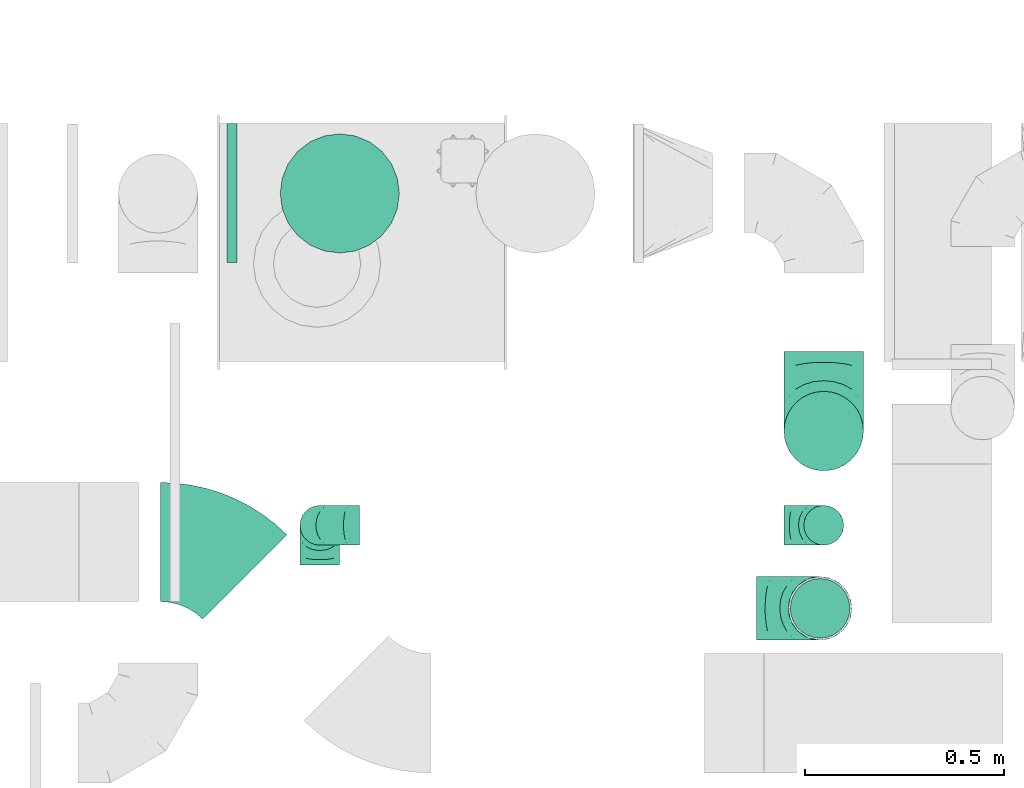
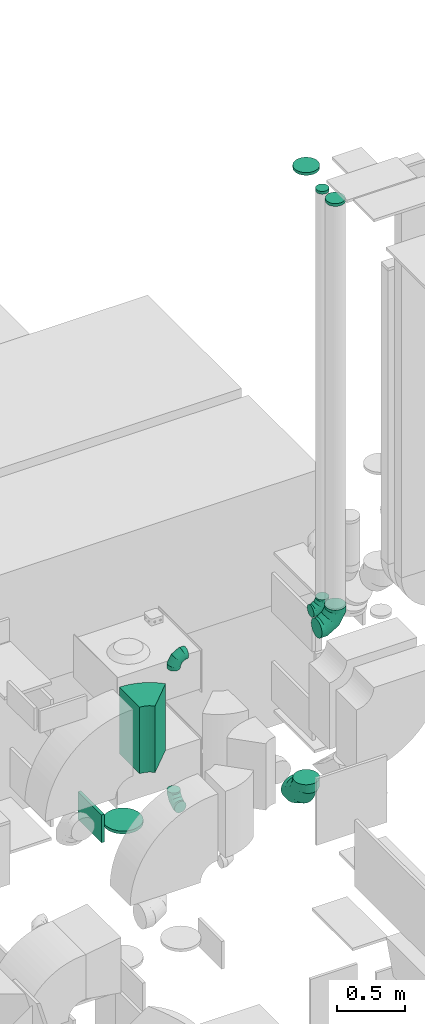
# One storey, part 18 of 59: 11 flow fittings.
"""IFC2X3 building model written with IfcOpenShell, lengths in millimetres."""

from ifc_helpers import new_model, entity, si_unit, converted_unit, derived_unit, direction, frame, frame_2d, origin, origin_2d_with_axis, place, context, subcontext, project, spatial, polyline, circle_curve, parameter, trimmed, segment, composite_curve, rectangle, circle, outline, extrude, faceted_brep, source, transform, mapped, material, type_object, type_shapes, element, save


model = new_model("IFC2X3")

# Units and contexts
model_context = context("Model", 3, precision=0.01, world=origin(), true_north=direction((6.12303176911189e-17, 1.0)))
body_context = subcontext(model_context, "Body", "Model", "MODEL_VIEW")
ifc_project = project(units=[si_unit("LENGTHUNIT", "METRE", prefix="MILLI"), si_unit("AREAUNIT", "SQUARE_METRE"), si_unit("VOLUMEUNIT", "CUBIC_METRE"), converted_unit("PLANEANGLEUNIT", "DEGREE", entity("IfcRatioMeasure", 0.0174532925199433), si_unit("PLANEANGLEUNIT", "RADIAN"), dimensions=[0, 0, 0, 0, 0, 0, 0]), si_unit("MASSUNIT", "GRAM", prefix="KILO"), derived_unit("MASSDENSITYUNIT", [(si_unit("MASSUNIT", "GRAM", prefix="KILO"), 1), (si_unit("LENGTHUNIT", "METRE"), -3)]), derived_unit("MOMENTOFINERTIAUNIT", [(si_unit("LENGTHUNIT", "METRE"), 4)]), si_unit("TIMEUNIT", "SECOND"), si_unit("FREQUENCYUNIT", "HERTZ"), si_unit("THERMODYNAMICTEMPERATUREUNIT", "DEGREE_CELSIUS"), derived_unit("THERMALTRANSMITTANCEUNIT", [(si_unit("MASSUNIT", "GRAM", prefix="KILO"), 1), (si_unit("THERMODYNAMICTEMPERATUREUNIT", "KELVIN"), -1), (si_unit("TIMEUNIT", "SECOND"), -3)]), derived_unit("VOLUMETRICFLOWRATEUNIT", [(si_unit("LENGTHUNIT", "METRE"), 3), (si_unit("TIMEUNIT", "SECOND"), -1)]), derived_unit("MASSFLOWRATEUNIT", [(si_unit("MASSUNIT", "GRAM", prefix="KILO"), 1), (si_unit("TIMEUNIT", "SECOND"), -1)]), derived_unit("ROTATIONALFREQUENCYUNIT", [(si_unit("TIMEUNIT", "SECOND"), -1)]), si_unit("ELECTRICCURRENTUNIT", "AMPERE"), si_unit("ELECTRICVOLTAGEUNIT", "VOLT"), si_unit("POWERUNIT", "WATT"), si_unit("FORCEUNIT", "NEWTON", prefix="KILO"), si_unit("ILLUMINANCEUNIT", "LUX"), si_unit("LUMINOUSFLUXUNIT", "LUMEN"), si_unit("LUMINOUSINTENSITYUNIT", "CANDELA"), derived_unit("USERDEFINED", [(si_unit("MASSUNIT", "GRAM", prefix="KILO"), -1), (si_unit("LENGTHUNIT", "METRE"), -2), (si_unit("TIMEUNIT", "SECOND"), 3), (si_unit("LUMINOUSFLUXUNIT", "LUMEN"), 1)]), derived_unit("LINEARVELOCITYUNIT", [(si_unit("LENGTHUNIT", "METRE"), 1), (si_unit("TIMEUNIT", "SECOND"), -1)]), si_unit("PRESSUREUNIT", "PASCAL"), derived_unit("USERDEFINED", [(si_unit("LENGTHUNIT", "METRE"), -2), (si_unit("MASSUNIT", "GRAM", prefix="KILO"), 1), (si_unit("TIMEUNIT", "SECOND"), -2)]), derived_unit("LINEARFORCEUNIT", [(si_unit("MASSUNIT", "GRAM", prefix="KILO"), 1), (si_unit("LENGTHUNIT", "METRE"), 1), (si_unit("TIMEUNIT", "SECOND"), -2), (si_unit("LENGTHUNIT", "METRE"), -1)]), derived_unit("PLANARFORCEUNIT", [(si_unit("MASSUNIT", "GRAM", prefix="KILO"), 1), (si_unit("LENGTHUNIT", "METRE"), 1), (si_unit("TIMEUNIT", "SECOND"), -2), (si_unit("LENGTHUNIT", "METRE"), -2)])], contexts=[model_context])

# Site, building, storey
site_placement = place(None, origin())
site = spatial("IfcSite", under=ifc_project, at=site_placement, CompositionType="ELEMENT")
building_placement = place(site_placement, origin())
building = spatial("IfcBuilding", under=site, at=building_placement, CompositionType="ELEMENT")
storey_placement = place(building_placement, frame((0.0, 0.0, 28200.0)))
storey = spatial("IfcBuildingStorey", under=building, at=storey_placement, CompositionType="ELEMENT", Elevation=28200.0)

# Flow fittings
ifc_material = material()
duct_fitting_type_1 = type_object("IfcDuctFittingType", PredefinedType="NOTDEFINED", material=ifc_material)
shared_shape_1 = source(origin(), body_context, "Body", "SweptSolid", [
    extrude(circle(Radius=49.9999999999997, at=origin_2d_with_axis()), frame((0.0, 0.0, 0.0), z_axis=(1.0, 0.0, 0.0), x_axis=(0.0, 1.0, 0.0)), (0.0, 0.0, 1.0), 25.0000000000018),
])
type_shapes(duct_fitting_type_1, [shared_shape_1])
flow_fitting_1_placement = place(storey_placement, frame((48370.11, 12162.74, 7463.42), z_axis=(-1.0, 0.0, 0.0), x_axis=(0.0, 0.0, 1.0)))
element("IfcFlowFitting", 1, at=flow_fitting_1_placement, inside=storey, type_object=duct_fitting_type_1, material=ifc_material, context=body_context, shape_type="MappedRepresentation", body=[
    mapped(shared_shape_1, transform((0.0, 0.0, 0.0), scale=1.0)),
])
duct_fitting_type_2 = type_object("IfcDuctFittingType", PredefinedType="NOTDEFINED", material=ifc_material)
shared_shape_2 = source(origin(), body_context, "Body", "SweptSolid", [
    extrude(circle(Radius=99.9999999999994, at=origin_2d_with_axis()), frame((0.0, 0.0, 0.0), z_axis=(1.0, 0.0, 0.0), x_axis=(0.0, 1.0, 0.0)), (0.0, 0.0, 1.0), 25.0000000000018),
])
type_shapes(duct_fitting_type_2, [shared_shape_2])
flow_fitting_2_placement = place(storey_placement, frame((48370.11, 12400.0, 7525.0), z_axis=(0.0, -1.0, 0.0), x_axis=(0.0, 0.0, 1.0)))
element("IfcFlowFitting", 2, at=flow_fitting_2_placement, inside=storey, type_object=duct_fitting_type_2, material=ifc_material, context=body_context, shape_type="MappedRepresentation", body=[
    mapped(shared_shape_2, transform((0.0, 0.0, 0.0), scale=1.0)),
])
duct_fitting_type_3 = type_object("IfcDuctFittingType", PredefinedType="NOTDEFINED", material=ifc_material)
shared_shape_3 = source(origin(), body_context, "Body", "SweptSolid", [
    extrude(rectangle(XDim=24.9999999999999, YDim=350.0, at=origin_2d_with_axis()), frame((12.5, 0.0, -125.0)), (0.0, 0.0, 1.0), 250.0),
])
type_shapes(duct_fitting_type_3, [shared_shape_3])
flow_fitting_3_placement = place(storey_placement, frame((46892.82, 12999.59, 1825.0), z_axis=(0.0, 0.0, 1.0), x_axis=(-1.0, 0.0, 0.0)))
element("IfcFlowFitting", 3, at=flow_fitting_3_placement, inside=storey, type_object=duct_fitting_type_3, material=ifc_material, context=body_context, shape_type="MappedRepresentation", body=[
    mapped(shared_shape_3, transform((0.0, 0.0, 0.0), scale=1.0)),
])
duct_fitting_type_4 = type_object("IfcDuctFittingType", PredefinedType="NOTDEFINED", material=ifc_material)
shared_shape_4 = source(origin(), body_context, "Body", "SweptSolid", [
    extrude(circle(Radius=74.9999999999995, at=origin_2d_with_axis()), frame((0.0, 0.0, 0.0), z_axis=(1.0, 0.0, 0.0), x_axis=(0.0, 1.0, 0.0)), (0.0, 0.0, 1.0), 25.0000000000018),
])
type_shapes(duct_fitting_type_4, [shared_shape_4])
flow_fitting_4_placement = place(storey_placement, frame((48361.04, 11953.77, 7501.2), z_axis=(-1.0, 0.0, 0.0), x_axis=(0.0, 0.0, 1.0)))
element("IfcFlowFitting", 4, at=flow_fitting_4_placement, inside=storey, type_object=duct_fitting_type_4, material=ifc_material, context=body_context, shape_type="MappedRepresentation", body=[
    mapped(shared_shape_4, transform((0.0, 0.0, 0.0), scale=1.0)),
])
duct_fitting_type_5 = type_object("IfcDuctFittingType", PredefinedType="NOTDEFINED", material=ifc_material)
shared_shape_5 = source(origin(), body_context, "Body", "Brep", [
    faceted_brep([(-160.0, 0.0, -80.0), (-160.0, -20.71, -77.27), (-160.0, -40.0, -69.28), (-160.0, -56.57, -56.57), (-160.0, -69.28, -40.0), (-160.0, -77.27, -20.71), (-160.0, -80.0, 0.0), (-160.0, -77.27, 20.71), (-160.0, -69.28, 40.0), (-160.0, -56.57, 56.57), (-160.0, -40.0, 69.28), (-160.0, -20.71, 77.27), (-160.0, 0.0, 80.0), (-160.0, 20.71, 77.27), (-160.0, 40.0, 69.28), (-160.0, 56.57, 56.57), (-160.0, 69.28, 40.0), (-160.0, 77.27, 20.71), (-160.0, 80.0, 0.0), (-160.0, 77.27, -20.71), (-160.0, 69.28, -40.0), (-160.0, 56.57, -56.57), (-160.0, 40.0, -69.28), (-160.0, 20.71, -77.27), (-122.68, 20.71, 77.27), (-127.85, 40.0, 69.28), (-117.13, 0.0, 80.0), (-132.29, 56.57, 56.57), (-137.83, 77.27, 20.71), (-138.56, 80.0, 0.0), (-135.69, 69.28, 40.0), (-135.69, 69.28, -40.0), (-132.29, 56.57, -56.57), (-137.83, 77.27, -20.71), (-122.68, 20.71, -77.27), (-117.13, 0.0, -80.0), (-127.85, 40.0, -69.28), (-111.58, -20.71, -77.27), (-106.41, -40.0, -69.28), (-101.97, -56.57, -56.57), (-98.56, -69.28, -40.0), (-96.42, -77.27, -20.71), (-95.69, -80.0, 0.0), (-96.42, -77.27, 20.71), (-98.56, -69.28, 40.0), (-101.97, -56.57, 56.57), (-106.41, -40.0, 69.28), (-111.58, -20.71, 77.27), (-58.03, 58.03, 77.27), (-72.15, 72.15, 69.28), (-42.87, 42.87, 80.0), (-84.28, 84.28, 56.57), (-93.59, 93.59, 40.0), (-99.44, 99.44, 20.71), (-101.44, 101.44, 0.0), (-99.44, 99.44, -20.71), (-93.59, 93.59, -40.0), (-84.28, 84.28, -56.57), (-58.03, 58.03, -77.27), (-42.87, 42.87, -80.0), (-72.15, 72.15, -69.28), (-27.71, 27.71, -77.27), (-13.59, 13.59, -69.28), (-1.46, 1.46, -56.57), (7.85, -7.85, -40.0), (13.7, -13.7, -20.71), (15.69, -15.69, 0.0), (13.7, -13.7, 20.71), (7.85, -7.85, 40.0), (-1.46, 1.46, 56.57), (-13.59, 13.59, 69.28), (-27.71, 27.71, 77.27), (-20.71, 122.68, 77.27), (-40.0, 127.85, 69.28), (0.0, 117.13, 80.0), (-56.57, 132.29, 56.57), (-69.28, 135.69, 40.0), (-77.27, 137.83, 20.71), (-80.0, 138.56, 0.0), (-77.27, 137.83, -20.71), (-69.28, 135.69, -40.0), (-56.57, 132.29, -56.57), (-20.71, 122.68, -77.27), (0.0, 117.13, -80.0), (-40.0, 127.85, -69.28), (20.71, 111.58, -77.27), (40.0, 106.41, -69.28), (56.57, 101.97, -56.57), (69.28, 98.56, -40.0), (77.27, 96.42, -20.71), (80.0, 95.69, 0.0), (77.27, 96.42, 20.71), (69.28, 98.56, 40.0), (56.57, 101.97, 56.57), (40.0, 106.41, 69.28), (20.71, 111.58, 77.27), (-20.71, 160.0, -77.27), (-40.0, 160.0, -69.28), (-56.57, 160.0, -56.57), (-69.28, 160.0, -40.0), (-77.27, 160.0, -20.71), (-80.0, 160.0, 0.0), (-77.27, 160.0, 20.71), (-69.28, 160.0, 40.0), (-56.57, 160.0, 56.57), (-40.0, 160.0, 69.28), (-20.71, 160.0, 77.27), (0.0, 160.0, 80.0), (20.71, 160.0, 77.27), (40.0, 160.0, 69.28), (56.57, 160.0, 56.57), (69.28, 160.0, 40.0), (77.27, 160.0, 20.71), (80.0, 160.0, 0.0), (77.27, 160.0, -20.71), (69.28, 160.0, -40.0), (56.57, 160.0, -56.57), (40.0, 160.0, -69.28), (20.71, 160.0, -77.27), (0.0, 160.0, -80.0)], [[[0, 1, 2, 3, 4, 5, 6, 7, 8, 9, 10, 11, 12, 13, 14, 15, 16, 17, 18, 19, 20, 21, 22, 23]], [[24, 25, 14, 13]], [[26, 24, 13, 12]], [[14, 25, 27, 15]], [[28, 29, 18, 17]], [[30, 28, 17, 16]], [[15, 27, 30, 16]], [[20, 31, 32, 21]], [[33, 31, 20, 19]], [[18, 29, 33, 19]], [[34, 35, 0, 23]], [[36, 34, 23, 22]], [[32, 36, 22, 21]], [[1, 0, 35, 37]], [[2, 1, 37, 38]], [[3, 2, 38, 39]], [[5, 4, 40, 41]], [[6, 5, 41, 42]], [[39, 40, 4, 3]], [[6, 42, 43, 7]], [[7, 43, 44, 8]], [[8, 44, 45, 9]], [[9, 45, 46, 10]], [[10, 46, 47, 11]], [[26, 12, 11, 47]], [[48, 49, 25, 24]], [[50, 48, 24, 26]], [[27, 25, 49, 51]], [[52, 53, 28, 30]], [[51, 52, 30, 27]], [[29, 28, 53, 54]], [[55, 56, 31, 33]], [[54, 55, 33, 29]], [[32, 31, 56, 57]], [[58, 59, 35, 34]], [[60, 58, 34, 36]], [[57, 60, 36, 32]], [[37, 35, 59, 61]], [[38, 37, 61, 62]], [[39, 38, 62, 63]], [[41, 40, 64, 65]], [[42, 41, 65, 66]], [[63, 64, 40, 39]], [[43, 42, 66, 67]], [[44, 43, 67, 68]], [[68, 69, 45, 44]], [[46, 45, 69, 70]], [[47, 46, 70, 71]], [[26, 47, 71, 50]], [[72, 73, 49, 48]], [[74, 72, 48, 50]], [[51, 49, 73, 75]], [[76, 77, 53, 52]], [[75, 76, 52, 51]], [[54, 53, 77, 78]], [[79, 80, 56, 55]], [[78, 79, 55, 54]], [[57, 56, 80, 81]], [[82, 83, 59, 58]], [[84, 82, 58, 60]], [[81, 84, 60, 57]], [[61, 59, 83, 85]], [[62, 61, 85, 86]], [[63, 62, 86, 87]], [[65, 64, 88, 89]], [[66, 65, 89, 90]], [[87, 88, 64, 63]], [[67, 66, 90, 91]], [[68, 67, 91, 92]], [[92, 93, 69, 68]], [[70, 69, 93, 94]], [[71, 70, 94, 95]], [[50, 71, 95, 74]], [[96, 97, 98, 99, 100, 101, 102, 103, 104, 105, 106, 107, 108, 109, 110, 111, 112, 113, 114, 115, 116, 117, 118, 119]], [[72, 74, 107, 106]], [[73, 72, 106, 105]], [[75, 73, 105, 104]], [[77, 76, 103, 102]], [[78, 77, 102, 101]], [[75, 104, 103, 76]], [[78, 101, 100, 79]], [[79, 100, 99, 80]], [[80, 99, 98, 81]], [[84, 97, 96, 82]], [[82, 96, 119, 83]], [[84, 81, 98, 97]], [[118, 117, 86, 85]], [[119, 118, 85, 83]], [[116, 87, 86, 117]], [[88, 115, 114, 89]], [[89, 114, 113, 90]], [[115, 88, 87, 116]], [[112, 111, 92, 91]], [[113, 112, 91, 90]], [[111, 110, 93, 92]], [[95, 94, 109, 108]], [[74, 95, 108, 107]], [[110, 109, 94, 93]]]),
])
type_shapes(duct_fitting_type_5, [shared_shape_5])
flow_fitting_5_placement = place(storey_placement, frame((48361.04, 11953.77, 3700.0), z_axis=(0.0, -1.0, 0.0), x_axis=(1.0, 0.0, 0.0)))
element("IfcFlowFitting", 5, at=flow_fitting_5_placement, inside=storey, type_object=duct_fitting_type_5, material=ifc_material, context=body_context, shape_type="MappedRepresentation", body=[
    mapped(shared_shape_5, transform((0.0, 0.0, 0.0), scale=1.0)),
])
duct_fitting_type_6 = type_object("IfcDuctFittingType", PredefinedType="NOTDEFINED", material=ifc_material)
shared_shape_6 = source(origin(), body_context, "Body", "Brep", [
    faceted_brep([(-100.0, 0.0, -50.0), (-100.0, -12.94, -48.3), (-100.0, -25.0, -43.3), (-100.0, -35.36, -35.36), (-100.0, -43.3, -25.0), (-100.0, -48.3, -12.94), (-100.0, -50.0, 0.0), (-100.0, -48.3, 12.94), (-100.0, -43.3, 25.0), (-100.0, -35.36, 35.36), (-100.0, -25.0, 43.3), (-100.0, -12.94, 48.3), (-100.0, 0.0, 50.0), (-100.0, 12.94, 48.3), (-100.0, 25.0, 43.3), (-100.0, 35.36, 35.36), (-100.0, 43.3, 25.0), (-100.0, 48.3, 12.94), (-100.0, 50.0, 0.0), (-100.0, 48.3, -12.94), (-100.0, 43.3, -25.0), (-100.0, 35.36, -35.36), (-100.0, 25.0, -43.3), (-100.0, 12.94, -48.3), (-76.67, 12.94, 48.3), (-79.9, 25.0, 43.3), (-73.21, 0.0, 50.0), (-82.68, 35.36, 35.36), (-86.15, 48.3, 12.94), (-86.6, 50.0, 0.0), (-84.81, 43.3, 25.0), (-84.81, 43.3, -25.0), (-82.68, 35.36, -35.36), (-86.15, 48.3, -12.94), (-76.67, 12.94, -48.3), (-73.21, 0.0, -50.0), (-79.9, 25.0, -43.3), (-69.74, -12.94, -48.3), (-66.51, -25.0, -43.3), (-63.73, -35.36, -35.36), (-61.6, -43.3, -25.0), (-60.26, -48.3, -12.94), (-59.81, -50.0, 0.0), (-60.26, -48.3, 12.94), (-61.6, -43.3, 25.0), (-63.73, -35.36, 35.36), (-66.51, -25.0, 43.3), (-69.74, -12.94, 48.3), (-36.27, 36.27, 48.3), (-45.1, 45.1, 43.3), (-26.79, 26.79, 50.0), (-52.68, 52.68, 35.36), (-58.49, 58.49, 25.0), (-62.15, 62.15, 12.94), (-63.4, 63.4, 0.0), (-62.15, 62.15, -12.94), (-58.49, 58.49, -25.0), (-52.68, 52.68, -35.36), (-36.27, 36.27, -48.3), (-26.79, 26.79, -50.0), (-45.1, 45.1, -43.3), (-17.32, 17.32, -48.3), (-8.49, 8.49, -43.3), (-0.91, 0.91, -35.36), (4.9, -4.9, -25.0), (8.56, -8.56, -12.94), (9.81, -9.81, 0.0), (8.56, -8.56, 12.94), (4.9, -4.9, 25.0), (-0.91, 0.91, 35.36), (-8.49, 8.49, 43.3), (-17.32, 17.32, 48.3), (-12.94, 76.67, 48.3), (-25.0, 79.9, 43.3), (0.0, 73.21, 50.0), (-35.36, 82.68, 35.36), (-43.3, 84.81, 25.0), (-48.3, 86.15, 12.94), (-50.0, 86.6, 0.0), (-48.3, 86.15, -12.94), (-43.3, 84.81, -25.0), (-35.36, 82.68, -35.36), (-12.94, 76.67, -48.3), (0.0, 73.21, -50.0), (-25.0, 79.9, -43.3), (12.94, 69.74, -48.3), (25.0, 66.51, -43.3), (35.36, 63.73, -35.36), (43.3, 61.6, -25.0), (48.3, 60.26, -12.94), (50.0, 59.81, 0.0), (48.3, 60.26, 12.94), (43.3, 61.6, 25.0), (35.36, 63.73, 35.36), (25.0, 66.51, 43.3), (12.94, 69.74, 48.3), (-12.94, 100.0, -48.3), (-25.0, 100.0, -43.3), (-35.36, 100.0, -35.36), (-43.3, 100.0, -25.0), (-48.3, 100.0, -12.94), (-50.0, 100.0, 0.0), (-48.3, 100.0, 12.94), (-43.3, 100.0, 25.0), (-35.36, 100.0, 35.36), (-25.0, 100.0, 43.3), (-12.94, 100.0, 48.3), (0.0, 100.0, 50.0), (12.94, 100.0, 48.3), (25.0, 100.0, 43.3), (35.36, 100.0, 35.36), (43.3, 100.0, 25.0), (48.3, 100.0, 12.94), (50.0, 100.0, 0.0), (48.3, 100.0, -12.94), (43.3, 100.0, -25.0), (35.36, 100.0, -35.36), (25.0, 100.0, -43.3), (12.94, 100.0, -48.3), (0.0, 100.0, -50.0)], [[[0, 1, 2, 3, 4, 5, 6, 7, 8, 9, 10, 11, 12, 13, 14, 15, 16, 17, 18, 19, 20, 21, 22, 23]], [[24, 25, 14, 13]], [[26, 24, 13, 12]], [[14, 25, 27, 15]], [[28, 29, 18, 17]], [[30, 28, 17, 16]], [[15, 27, 30, 16]], [[20, 31, 32, 21]], [[33, 31, 20, 19]], [[18, 29, 33, 19]], [[34, 35, 0, 23]], [[36, 34, 23, 22]], [[32, 36, 22, 21]], [[2, 1, 37, 38]], [[3, 2, 38, 39]], [[0, 35, 37, 1]], [[5, 4, 40, 41]], [[6, 5, 41, 42]], [[3, 39, 40, 4]], [[6, 42, 43, 7]], [[7, 43, 44, 8]], [[8, 44, 45, 9]], [[10, 46, 47, 11]], [[11, 47, 26, 12]], [[10, 9, 45, 46]], [[48, 49, 25, 24]], [[50, 48, 24, 26]], [[27, 25, 49, 51]], [[52, 53, 28, 30]], [[51, 52, 30, 27]], [[29, 28, 53, 54]], [[55, 56, 31, 33]], [[54, 55, 33, 29]], [[57, 32, 31, 56]], [[58, 59, 35, 34]], [[60, 58, 34, 36]], [[57, 60, 36, 32]], [[37, 35, 59, 61]], [[38, 37, 61, 62]], [[39, 38, 62, 63]], [[41, 40, 64, 65]], [[42, 41, 65, 66]], [[63, 64, 40, 39]], [[43, 42, 66, 67]], [[44, 43, 67, 68]], [[68, 69, 45, 44]], [[46, 45, 69, 70]], [[47, 46, 70, 71]], [[26, 47, 71, 50]], [[72, 73, 49, 48]], [[74, 72, 48, 50]], [[51, 49, 73, 75]], [[76, 77, 53, 52]], [[75, 76, 52, 51]], [[54, 53, 77, 78]], [[79, 80, 56, 55]], [[78, 79, 55, 54]], [[81, 57, 56, 80]], [[82, 83, 59, 58]], [[84, 82, 58, 60]], [[81, 84, 60, 57]], [[61, 59, 83, 85]], [[62, 61, 85, 86]], [[63, 62, 86, 87]], [[65, 64, 88, 89]], [[66, 65, 89, 90]], [[87, 88, 64, 63]], [[67, 66, 90, 91]], [[68, 67, 91, 92]], [[92, 93, 69, 68]], [[70, 69, 93, 94]], [[71, 70, 94, 95]], [[50, 71, 95, 74]], [[96, 97, 98, 99, 100, 101, 102, 103, 104, 105, 106, 107, 108, 109, 110, 111, 112, 113, 114, 115, 116, 117, 118, 119]], [[72, 74, 107, 106]], [[73, 72, 106, 105]], [[75, 73, 105, 104]], [[77, 76, 103, 102]], [[78, 77, 102, 101]], [[75, 104, 103, 76]], [[78, 101, 100, 79]], [[79, 100, 99, 80]], [[80, 99, 98, 81]], [[96, 119, 83, 82]], [[97, 96, 82, 84]], [[84, 81, 98, 97]], [[83, 119, 118, 85]], [[85, 118, 117, 86]], [[86, 117, 116, 87]], [[88, 115, 114, 89]], [[89, 114, 113, 90]], [[87, 116, 115, 88]], [[91, 90, 113, 112]], [[92, 91, 112, 111]], [[93, 92, 111, 110]], [[95, 94, 109, 108]], [[74, 95, 108, 107]], [[110, 109, 94, 93]]]),
])
type_shapes(duct_fitting_type_6, [shared_shape_6])
for number, where, z_axis, x_axis in (
    (6, (48370.11, 12162.74, 3703.42), (0.0, -1.0, 0.0), (1.0, 0.0, 0.0)),
    (7, (47101.64, 12162.74, 3703.42), (0.0, -1.0, 0.0), (-1.0, 0.0, 0.0)),
    (8, (47101.64, 12162.74, 2403.42), (-1.0, 0.0, 0.0), (0.0, 0.0, -1.0)),
):
    element("IfcFlowFitting", number, at=place(storey_placement, frame(where, z_axis=z_axis, x_axis=x_axis)), inside=storey, type_object=duct_fitting_type_6, material=ifc_material, context=body_context, shape_type="MappedRepresentation", body=[
        mapped(shared_shape_6, transform((0.0, 0.0, 0.0), scale=1.0)),
    ])
duct_fitting_type_7 = type_object("IfcDuctFittingType", PredefinedType="NOTDEFINED", material=ifc_material)
shared_shape_7 = source(origin(), body_context, "Body", "Brep", [
    faceted_brep([(-200.0, 0.0, -100.0), (-200.0, -25.88, -96.59), (-200.0, -50.0, -86.6), (-200.0, -70.71, -70.71), (-200.0, -86.6, -50.0), (-200.0, -96.59, -25.88), (-200.0, -100.0, 0.0), (-200.0, -96.59, 25.88), (-200.0, -86.6, 50.0), (-200.0, -70.71, 70.71), (-200.0, -50.0, 86.6), (-200.0, -25.88, 96.59), (-200.0, 0.0, 100.0), (-200.0, 25.88, 96.59), (-200.0, 50.0, 86.6), (-200.0, 70.71, 70.71), (-200.0, 86.6, 50.0), (-200.0, 96.59, 25.88), (-200.0, 100.0, 0.0), (-200.0, 96.59, -25.88), (-200.0, 86.6, -50.0), (-200.0, 70.71, -70.71), (-200.0, 50.0, -86.6), (-200.0, 25.88, -96.59), (-153.35, 25.88, 96.59), (-159.81, 50.0, 86.6), (-146.41, 0.0, 100.0), (-165.36, 70.71, 70.71), (-172.29, 96.59, 25.88), (-173.21, 100.0, 0.0), (-169.62, 86.6, 50.0), (-169.62, 86.6, -50.0), (-165.36, 70.71, -70.71), (-172.29, 96.59, -25.88), (-153.35, 25.88, -96.59), (-146.41, 0.0, -100.0), (-159.81, 50.0, -86.6), (-139.48, -25.88, -96.59), (-133.01, -50.0, -86.6), (-127.46, -70.71, -70.71), (-123.21, -86.6, -50.0), (-120.53, -96.59, -25.88), (-119.62, -100.0, 0.0), (-120.53, -96.59, 25.88), (-123.21, -86.6, 50.0), (-127.46, -70.71, 70.71), (-133.01, -50.0, 86.6), (-139.48, -25.88, 96.59), (-72.54, 72.54, 96.59), (-90.19, 90.19, 86.6), (-53.59, 53.59, 100.0), (-105.35, 105.35, 70.71), (-116.99, 116.99, 50.0), (-124.3, 124.3, 25.88), (-126.79, 126.79, 0.0), (-124.3, 124.3, -25.88), (-116.99, 116.99, -50.0), (-105.35, 105.35, -70.71), (-72.54, 72.54, -96.59), (-53.59, 53.59, -100.0), (-90.19, 90.19, -86.6), (-34.64, 34.64, -96.59), (-16.99, 16.99, -86.6), (-1.83, 1.83, -70.71), (9.81, -9.81, -50.0), (17.12, -17.12, -25.88), (19.62, -19.62, 0.0), (17.12, -17.12, 25.88), (9.81, -9.81, 50.0), (-1.83, 1.83, 70.71), (-16.99, 16.99, 86.6), (-34.64, 34.64, 96.59), (-25.88, 153.35, 96.59), (-50.0, 159.81, 86.6), (0.0, 146.41, 100.0), (-70.71, 165.36, 70.71), (-86.6, 169.62, 50.0), (-96.59, 172.29, 25.88), (-100.0, 173.21, 0.0), (-96.59, 172.29, -25.88), (-86.6, 169.62, -50.0), (-70.71, 165.36, -70.71), (-25.88, 153.35, -96.59), (0.0, 146.41, -100.0), (-50.0, 159.81, -86.6), (25.88, 139.48, -96.59), (50.0, 133.01, -86.6), (70.71, 127.46, -70.71), (86.6, 123.21, -50.0), (96.59, 120.53, -25.88), (100.0, 119.62, 0.0), (96.59, 120.53, 25.88), (86.6, 123.21, 50.0), (70.71, 127.46, 70.71), (50.0, 133.01, 86.6), (25.88, 139.48, 96.59), (-25.88, 200.0, -96.59), (-50.0, 200.0, -86.6), (-70.71, 200.0, -70.71), (-86.6, 200.0, -50.0), (-96.59, 200.0, -25.88), (-100.0, 200.0, 0.0), (-96.59, 200.0, 25.88), (-86.6, 200.0, 50.0), (-70.71, 200.0, 70.71), (-50.0, 200.0, 86.6), (-25.88, 200.0, 96.59), (0.0, 200.0, 100.0), (25.88, 200.0, 96.59), (50.0, 200.0, 86.6), (70.71, 200.0, 70.71), (86.6, 200.0, 50.0), (96.59, 200.0, 25.88), (100.0, 200.0, 0.0), (96.59, 200.0, -25.88), (86.6, 200.0, -50.0), (70.71, 200.0, -70.71), (50.0, 200.0, -86.6), (25.88, 200.0, -96.59), (0.0, 200.0, -100.0)], [[[0, 1, 2, 3, 4, 5, 6, 7, 8, 9, 10, 11, 12, 13, 14, 15, 16, 17, 18, 19, 20, 21, 22, 23]], [[24, 25, 14, 13]], [[26, 24, 13, 12]], [[14, 25, 27, 15]], [[28, 29, 18, 17]], [[30, 28, 17, 16]], [[15, 27, 30, 16]], [[20, 31, 32, 21]], [[33, 31, 20, 19]], [[18, 29, 33, 19]], [[34, 35, 0, 23]], [[36, 34, 23, 22]], [[32, 36, 22, 21]], [[1, 0, 35, 37]], [[2, 1, 37, 38]], [[38, 39, 3, 2]], [[5, 4, 40, 41]], [[6, 5, 41, 42]], [[39, 40, 4, 3]], [[6, 42, 43, 7]], [[7, 43, 44, 8]], [[8, 44, 45, 9]], [[9, 45, 46, 10]], [[10, 46, 47, 11]], [[26, 12, 11, 47]], [[48, 49, 25, 24]], [[50, 48, 24, 26]], [[27, 25, 49, 51]], [[52, 53, 28, 30]], [[51, 52, 30, 27]], [[29, 28, 53, 54]], [[55, 56, 31, 33]], [[54, 55, 33, 29]], [[32, 31, 56, 57]], [[58, 59, 35, 34]], [[60, 58, 34, 36]], [[57, 60, 36, 32]], [[37, 35, 59, 61]], [[38, 37, 61, 62]], [[39, 38, 62, 63]], [[41, 40, 64, 65]], [[42, 41, 65, 66]], [[63, 64, 40, 39]], [[43, 42, 66, 67]], [[44, 43, 67, 68]], [[68, 69, 45, 44]], [[46, 45, 69, 70]], [[47, 46, 70, 71]], [[26, 47, 71, 50]], [[72, 73, 49, 48]], [[74, 72, 48, 50]], [[51, 49, 73, 75]], [[76, 77, 53, 52]], [[75, 76, 52, 51]], [[54, 53, 77, 78]], [[79, 80, 56, 55]], [[78, 79, 55, 54]], [[57, 56, 80, 81]], [[82, 83, 59, 58]], [[84, 82, 58, 60]], [[81, 84, 60, 57]], [[61, 59, 83, 85]], [[62, 61, 85, 86]], [[63, 62, 86, 87]], [[65, 64, 88, 89]], [[66, 65, 89, 90]], [[87, 88, 64, 63]], [[67, 66, 90, 91]], [[68, 67, 91, 92]], [[92, 93, 69, 68]], [[70, 69, 93, 94]], [[71, 70, 94, 95]], [[50, 71, 95, 74]], [[96, 97, 98, 99, 100, 101, 102, 103, 104, 105, 106, 107, 108, 109, 110, 111, 112, 113, 114, 115, 116, 117, 118, 119]], [[72, 74, 107, 106]], [[73, 72, 106, 105]], [[75, 73, 105, 104]], [[102, 101, 78, 77]], [[103, 102, 77, 76]], [[75, 104, 103, 76]], [[78, 101, 100, 79]], [[79, 100, 99, 80]], [[80, 99, 98, 81]], [[84, 97, 96, 82]], [[82, 96, 119, 83]], [[84, 81, 98, 97]], [[118, 117, 86, 85]], [[119, 118, 85, 83]], [[116, 87, 86, 117]], [[88, 115, 114, 89]], [[89, 114, 113, 90]], [[115, 88, 87, 116]], [[91, 90, 113, 112]], [[92, 91, 112, 111]], [[111, 110, 93, 92]], [[95, 94, 109, 108]], [[74, 95, 108, 107]], [[110, 109, 94, 93]]]),
])
type_shapes(duct_fitting_type_7, [shared_shape_7])
flow_fitting_6_placement = place(storey_placement, frame((48370.11, 12400.0, 1825.0), z_axis=(-1.0, 0.0, 0.0), x_axis=(0.0, -1.0, 0.0)))
element("IfcFlowFitting", 9, at=flow_fitting_6_placement, inside=storey, type_object=duct_fitting_type_7, material=ifc_material, context=body_context, shape_type="MappedRepresentation", body=[
    mapped(shared_shape_7, transform((0.0, 0.0, 0.0), scale=1.0)),
])
duct_fitting_type_8 = type_object("IfcDuctFittingType", PredefinedType="NOTDEFINED", material=ifc_material)
shared_shape_8 = source(origin(), body_context, "Body", "Brep", [
    faceted_brep([(20.0, 0.0, -150.0), (20.0, 38.82, -144.89), (20.0, 75.0, -129.9), (20.0, 106.07, -106.07), (20.0, 129.9, -75.0), (20.0, 144.89, -38.82), (20.0, 150.0, 0.0), (20.0, 144.89, 38.82), (20.0, 129.9, 75.0), (20.0, 106.07, 106.07), (20.0, 75.0, 129.9), (20.0, 38.82, 144.89), (20.0, 0.0, 150.0), (20.0, -38.82, 144.89), (20.0, -75.0, 129.9), (20.0, -106.07, 106.07), (20.0, -129.9, 75.0), (20.0, -144.89, 38.82), (20.0, -150.0, 0.0), (20.0, -144.89, -38.82), (20.0, -129.9, -75.0), (20.0, -106.07, -106.07), (20.0, -75.0, -129.9), (20.0, -38.82, -144.89), (0.0, 0.0, 150.0), (-6.1, 0.0, 150.0), (-6.1, -38.82, 144.89), (0.0, -38.82, 144.89), (-6.1, -75.0, 129.9), (0.0, -75.0, 129.9), (0.0, -106.07, 106.07), (-6.1, -106.07, 106.07), (0.0, -129.9, 75.0), (-6.1, -129.9, 75.0), (-6.1, -144.89, 38.82), (0.0, -144.89, 38.82), (-6.1, -150.0, 0.0), (0.0, -150.0, 0.0), (-6.1, -144.89, -38.82), (0.0, -144.89, -38.82), (-6.1, -129.9, -75.0), (0.0, -129.9, -75.0), (0.0, -106.07, -106.07), (-6.1, -106.07, -106.07), (0.0, -75.0, -129.9), (-6.1, -75.0, -129.9), (-6.1, -38.82, -144.89), (0.0, -38.82, -144.89), (-6.1, 0.0, -150.0), (0.0, 0.0, -150.0), (-6.1, 38.82, -144.89), (0.0, 38.82, -144.89), (-6.1, 75.0, -129.9), (0.0, 75.0, -129.9), (0.0, 106.07, -106.07), (-6.1, 106.07, -106.07), (0.0, 129.9, -75.0), (-6.1, 129.9, -75.0), (-6.1, 144.89, -38.82), (0.0, 144.89, -38.82), (-6.1, 150.0, 0.0), (0.0, 150.0, 0.0), (-6.1, 144.89, 38.82), (0.0, 144.89, 38.82), (-6.1, 129.9, 75.0), (0.0, 129.9, 75.0), (0.0, 106.07, 106.07), (-6.1, 106.07, 106.07), (0.0, 75.0, 129.9), (-6.1, 75.0, 129.9), (-6.1, 38.82, 144.89), (0.0, 38.82, 144.89)], [[[0, 1, 2, 3, 4, 5, 6, 7, 8, 9, 10, 11, 12, 13, 14, 15, 16, 17, 18, 19, 20, 21, 22, 23]], [[13, 12, 24, 25, 26, 27]], [[14, 13, 27, 26, 28, 29]], [[30, 15, 14, 29, 28, 31]], [[17, 16, 32, 33, 34, 35]], [[18, 17, 35, 34, 36, 37]], [[32, 16, 15, 30, 31, 33]], [[19, 18, 37, 36, 38, 39]], [[20, 19, 39, 38, 40, 41]], [[42, 21, 20, 41, 40, 43]], [[23, 22, 44, 45, 46, 47]], [[0, 23, 47, 46, 48, 49]], [[44, 22, 21, 42, 43, 45]], [[1, 0, 49, 48, 50, 51]], [[2, 1, 51, 50, 52, 53]], [[54, 3, 2, 53, 52, 55]], [[5, 4, 56, 57, 58, 59]], [[6, 5, 59, 58, 60, 61]], [[56, 4, 3, 54, 55, 57]], [[7, 6, 61, 60, 62, 63]], [[8, 7, 63, 62, 64, 65]], [[66, 9, 8, 65, 64, 67]], [[11, 10, 68, 69, 70, 71]], [[12, 11, 71, 70, 25, 24]], [[68, 10, 9, 66, 67, 69]], [[46, 45, 43, 40, 38, 36, 34, 33, 31, 28, 26, 25, 70, 69, 67, 64, 62, 60, 58, 57, 55, 52, 50, 48]]]),
])
type_shapes(duct_fitting_type_8, [shared_shape_8])
flow_fitting_7_placement = place(storey_placement, frame((47151.97, 12998.12, 1700.0), z_axis=(1.0, 0.0, 0.0), x_axis=(0.0, 0.0, -1.0)))
element("IfcFlowFitting", 10, at=flow_fitting_7_placement, inside=storey, type_object=duct_fitting_type_8, material=ifc_material, context=body_context, shape_type="MappedRepresentation", body=[
    mapped(shared_shape_8, transform((0.0, 0.0, 0.0), scale=1.0)),
])
duct_fitting_type_9 = type_object("IfcDuctFittingType", PredefinedType="NOTDEFINED", material=ifc_material)
shared_shape_9 = source(origin(), body_context, "Body", "SweptSolid", [
    extrude(outline(composite_curve([segment(polyline([(-193.93, -106.07), (106.07, -106.07)]), True, "CONTINUOUS"), segment(trimmed(circle_curve(frame_2d((256.07, -106.07), x_axis=(-0.707106781186553, 0.707106781186553)), 150.0), [parameter(0.0)], [parameter(45.0)], True, "PARAMETER"), False, "CONTINUOUS"), segment(polyline([(150.0, 0.0), (-62.13, 212.13)]), True, "CONTINUOUS"), segment(trimmed(circle_curve(frame_2d((256.07, -106.07), x_axis=(-0.707106781186553, 0.707106781186553)), 450.0), [parameter(0.0)], [parameter(45.0)], True, "PARAMETER"), True, "CONTINUOUS")], self_intersect=False)), frame((-18.2, 43.93, -300.0), z_axis=(0.0, 0.0, 1.0), x_axis=(-0.707106781186547, 0.707106781186548, 0.0)), (0.0, 0.0, 1.0), 600.0),
])
type_shapes(duct_fitting_type_9, [shared_shape_9])
flow_fitting_8_placement = place(storey_placement, frame((46825.09, 12120.6, 3200.0), z_axis=(0.0, 0.0, 1.0), x_axis=(-0.707106781186531, 0.707106781186564, 0.0)))
element("IfcFlowFitting", 11, at=flow_fitting_8_placement, inside=storey, type_object=duct_fitting_type_9, material=ifc_material, context=body_context, shape_type="MappedRepresentation", body=[
    mapped(shared_shape_9, transform((0.0, 0.0, 0.0), scale=1.0)),
])

save(model, "model.ifc")
